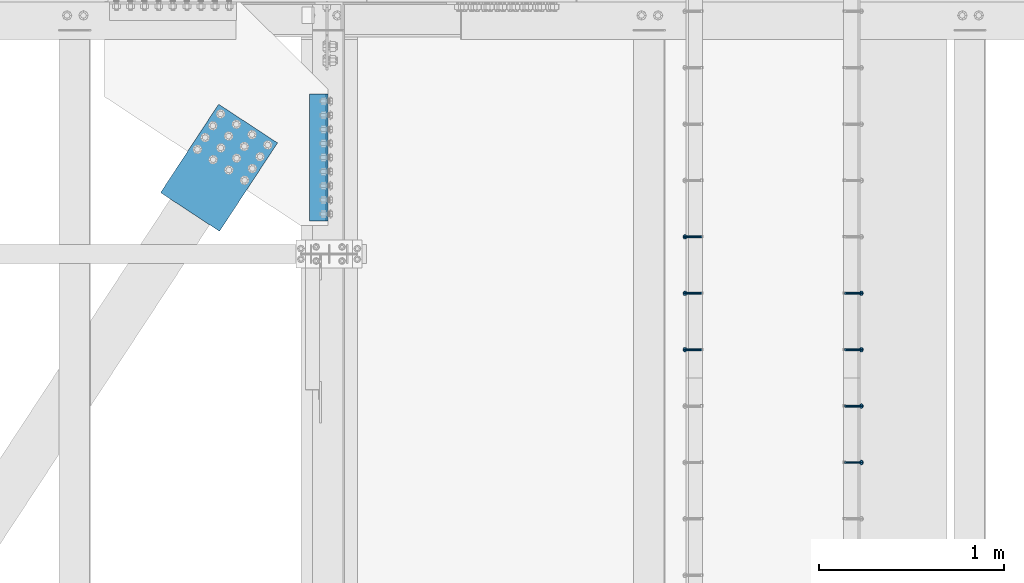
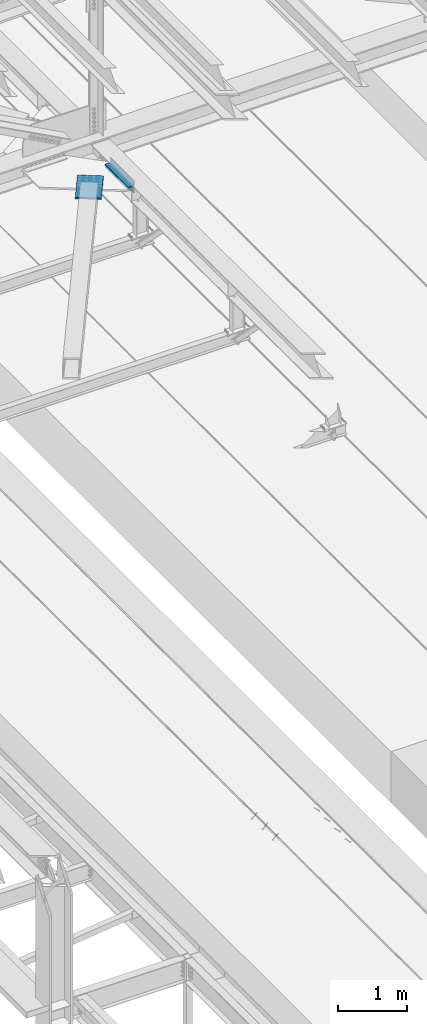
# One storey, part 2374 of 3843: 7 members, 3 beams, 5 elements without a shape of their own.
"""IFC2X3 building model written with IfcOpenShell, lengths in millimetres."""

from ifc_helpers import new_model, si_unit, frame, origin_with_axes, place, context, subcontext, project, spatial, faceted_brep, material, type_object, element, aggregate, save


model = new_model("IFC2X3")

# Units and contexts
model_context = context("Model", 3, precision=1e-05, world=origin_with_axes())
body_context = subcontext(model_context, "Body", "Model", "MODEL_VIEW")
ifc_project = project(units=[si_unit("LENGTHUNIT", "METRE", prefix="MILLI"), si_unit("AREAUNIT", "SQUARE_METRE"), si_unit("VOLUMEUNIT", "CUBIC_METRE"), si_unit("MASSUNIT", "GRAM", prefix="KILO"), si_unit("TIMEUNIT", "SECOND"), si_unit("PLANEANGLEUNIT", "RADIAN"), si_unit("SOLIDANGLEUNIT", "STERADIAN"), si_unit("THERMODYNAMICTEMPERATUREUNIT", "DEGREE_CELSIUS"), si_unit("LUMINOUSINTENSITYUNIT", "LUMEN")], contexts=[model_context])

# Site, building, storey
site_placement = place(None, origin_with_axes())
site = spatial("IfcSite", under=ifc_project, at=site_placement, CompositionType="ELEMENT")
building_placement = place(site_placement, origin_with_axes())
building = spatial("IfcBuilding", under=site, at=building_placement, Name="Undefined", CompositionType="ELEMENT")
storey_placement = place(building_placement, origin_with_axes())
storey = spatial("IfcBuildingStorey", under=building, at=storey_placement, Name="Undefined", CompositionType="ELEMENT", Elevation=0.0)

# Assembly, members
assembly_1_placement = place(storey_placement, origin_with_axes())
assembly_1 = element("IfcElementAssembly", 1, at=assembly_1_placement, inside=storey, Name="EMBED_ANGLE", AssemblyPlace="NOTDEFINED", PredefinedType="RIGID_FRAME")
ifc_material_1 = material(Name="STEEL/A108")
member_type = type_object("IfcMemberType", PredefinedType="NOTDEFINED")
member_1_placement = place(assembly_1_placement, frame((44851.3834999999, 64773.175189209, 30456.1875), z_axis=(0.0, 1.0, 0.0), x_axis=(0.707106781186548, 0.0, -0.707106781186548)))
member_1 = element("IfcMember", 2, at=member_1_placement, type_object=member_type, material=ifc_material_1, Name="HEADED STUD ANCHOR", context=body_context, shape_type="Brep", body=[
    faceted_brep([(7.27595761418343e-12, -3.18000006675175, 5.5), (0.0, -5.49999999998363, 3.1800000667572), (118.110000000976, -5.49999999999091, 3.1800000667572), (118.110000000983, -3.18000006675175, 5.5), (0.0, -6.3499999046162, 0.0), (118.110000000968, -6.34999990461256, 0.0), (0.0, -5.49999999998363, -3.1800000667572), (118.110000000976, -5.49999999999091, -3.1800000667572), (7.27595761418343e-12, -3.18000006675175, -5.5), (118.110000000983, -3.18000006675175, -5.5), (7.27595761418343e-12, -1.81898940354586e-12, -6.34999990463257), (118.110000000968, -1.81898940354586e-12, -6.34999990463257), (0.0, 3.18000006675175, -5.5), (118.110000000968, 3.18000006674811, -5.5), (7.27595761418343e-12, 5.49999999998363, -3.1800000667572), (118.110000000983, 5.49999999998363, -3.1800000667572), (7.27595761418343e-12, 6.3499999046162, 0.0), (118.110000000976, 6.34999990461256, 0.0), (7.27595761418343e-12, 5.49999999998363, 3.1800000667572), (118.110000000983, 5.49999999998363, 3.1800000667572), (0.0, 3.18000006675175, 5.5), (118.110000000968, 3.18000006674811, 5.5), (7.27595761418343e-12, -1.81898940354586e-12, 6.34999990463257), (118.110000000968, -1.81898940354586e-12, 6.34999990463257), (120.650000000991, -10.9899997710909, 6.34999990463257), (120.650000000998, -6.34000015257152, 10.9899997711182), (120.650000000991, -12.6999998092379, 0.0), (120.650000000991, -10.9899997710909, -6.34999990463257), (120.650000000998, -6.34000015257152, -10.9899997711182), (120.650000000991, -1.81898940354586e-12, -12.6899995803833), (120.650000000991, 6.34000015257152, -10.9899997711182), (120.650000000998, 10.9899997710909, -6.34999990463257), (120.650000000991, 12.6999998092342, 0.0), (120.650000000998, 10.9899997710909, 6.34999990463257), (120.650000000991, 6.34000015257152, 10.9899997711182), (120.650000000991, -1.81898940354586e-12, 12.6899995803833), (127.000000001048, -10.9899997710945, 6.34999990463257), (127.000000001048, -6.34000015257152, 10.9899997711182), (127.000000001048, -12.6999998092342, 0.0), (127.000000001048, -10.9899997710945, -6.34999990463257), (127.000000001048, -6.34000015257152, -10.9899997711182), (127.000000001048, 1.81898940354586e-12, -12.6899995803833), (127.000000001048, 6.34000015256788, -10.9899997711182), (127.000000001048, 10.9899997710909, -6.34999990463257), (127.000000001048, 12.6999998092379, 0.0), (127.000000001048, 10.9899997710909, 6.34999990463257), (127.000000001048, 6.34000015256788, 10.9899997711182), (127.000000001048, 1.81898940354586e-12, 12.6899995803833)], [[[0, 1, 2, 3]], [[1, 4, 5, 2]], [[4, 6, 7, 5]], [[6, 8, 9, 7]], [[8, 10, 11, 9]], [[10, 12, 13, 11]], [[12, 14, 15, 13]], [[14, 16, 17, 15]], [[16, 18, 19, 17]], [[18, 20, 21, 19]], [[20, 22, 23, 21]], [[22, 0, 3, 23]], [[22, 20, 18, 16, 14, 12, 10, 8, 6, 4, 1, 0]], [[3, 2, 24, 25]], [[2, 5, 26, 24]], [[5, 7, 27, 26]], [[7, 9, 28, 27]], [[9, 11, 29, 28]], [[11, 13, 30, 29]], [[13, 15, 31, 30]], [[15, 17, 32, 31]], [[17, 19, 33, 32]], [[19, 21, 34, 33]], [[21, 23, 35, 34]], [[23, 3, 25, 35]], [[25, 24, 36, 37]], [[24, 26, 38, 36]], [[26, 27, 39, 38]], [[27, 28, 40, 39]], [[28, 29, 41, 40]], [[29, 30, 42, 41]], [[30, 31, 43, 42]], [[31, 32, 44, 43]], [[32, 33, 45, 44]], [[33, 34, 46, 45]], [[34, 35, 47, 46]], [[35, 25, 37, 47]], [[38, 39, 40, 41, 42, 43, 44, 45, 46, 47, 37, 36]]]),
])
member_2_placement = place(assembly_1_placement, frame((44851.3834999999, 65077.975189209, 30456.1875), z_axis=(0.0, 1.0, 0.0), x_axis=(0.707106781186548, 0.0, -0.707106781186548)))
member_2 = element("IfcMember", 3, at=member_2_placement, type_object=member_type, material=ifc_material_1, Name="HEADED STUD ANCHOR", context=body_context, shape_type="Brep", body=[
    faceted_brep([(7.27595761418343e-12, -3.18000006675175, 5.5), (0.0, -5.49999999998363, 3.1800000667572), (118.110000000976, -5.49999999999091, 3.1800000667572), (118.110000000983, -3.18000006675175, 5.5), (0.0, -6.3499999046162, 0.0), (118.110000000968, -6.34999990461256, 0.0), (0.0, -5.49999999998363, -3.1800000667572), (118.110000000976, -5.49999999999091, -3.1800000667572), (7.27595761418343e-12, -3.18000006675175, -5.5), (118.110000000983, -3.18000006675175, -5.5), (7.27595761418343e-12, -1.81898940354586e-12, -6.34999990463257), (118.110000000968, -1.81898940354586e-12, -6.34999990463257), (0.0, 3.18000006675175, -5.5), (118.110000000968, 3.18000006674811, -5.5), (7.27595761418343e-12, 5.49999999998363, -3.1800000667572), (118.110000000983, 5.49999999998363, -3.1800000667572), (7.27595761418343e-12, 6.3499999046162, 0.0), (118.110000000976, 6.34999990461256, 0.0), (7.27595761418343e-12, 5.49999999998363, 3.1800000667572), (118.110000000983, 5.49999999998363, 3.1800000667572), (0.0, 3.18000006675175, 5.5), (118.110000000968, 3.18000006674811, 5.5), (7.27595761418343e-12, -1.81898940354586e-12, 6.34999990463257), (118.110000000968, -1.81898940354586e-12, 6.34999990463257), (120.650000000991, -10.9899997710909, 6.34999990463257), (120.650000000998, -6.34000015257152, 10.9899997711182), (120.650000000991, -12.6999998092379, 0.0), (120.650000000991, -10.9899997710909, -6.34999990463257), (120.650000000998, -6.34000015257152, -10.9899997711182), (120.650000000991, -1.81898940354586e-12, -12.6899995803833), (120.650000000991, 6.34000015257152, -10.9899997711182), (120.650000000998, 10.9899997710909, -6.34999990463257), (120.650000000991, 12.6999998092342, 0.0), (120.650000000998, 10.9899997710909, 6.34999990463257), (120.650000000991, 6.34000015257152, 10.9899997711182), (120.650000000991, -1.81898940354586e-12, 12.6899995803833), (127.000000001048, -10.9899997710945, 6.34999990463257), (127.000000001048, -6.34000015257152, 10.9899997711182), (127.000000001048, -12.6999998092342, 0.0), (127.000000001048, -10.9899997710945, -6.34999990463257), (127.000000001048, -6.34000015257152, -10.9899997711182), (127.000000001048, 1.81898940354586e-12, -12.6899995803833), (127.000000001048, 6.34000015256788, -10.9899997711182), (127.000000001048, 10.9899997710909, -6.34999990463257), (127.000000001048, 12.6999998092379, 0.0), (127.000000001048, 10.9899997710909, 6.34999990463257), (127.000000001048, 6.34000015256788, 10.9899997711182), (127.000000001048, 1.81898940354586e-12, 12.6899995803833)], [[[0, 1, 2, 3]], [[1, 4, 5, 2]], [[4, 6, 7, 5]], [[6, 8, 9, 7]], [[8, 10, 11, 9]], [[10, 12, 13, 11]], [[12, 14, 15, 13]], [[14, 16, 17, 15]], [[16, 18, 19, 17]], [[18, 20, 21, 19]], [[20, 22, 23, 21]], [[22, 0, 3, 23]], [[22, 20, 18, 16, 14, 12, 10, 8, 6, 4, 1, 0]], [[3, 2, 24, 25]], [[2, 5, 26, 24]], [[5, 7, 27, 26]], [[7, 9, 28, 27]], [[9, 11, 29, 28]], [[11, 13, 30, 29]], [[13, 15, 31, 30]], [[15, 17, 32, 31]], [[17, 19, 33, 32]], [[19, 21, 34, 33]], [[21, 23, 35, 34]], [[23, 3, 25, 35]], [[25, 24, 36, 37]], [[24, 26, 38, 36]], [[26, 27, 39, 38]], [[27, 28, 40, 39]], [[28, 29, 41, 40]], [[29, 30, 42, 41]], [[30, 31, 43, 42]], [[31, 32, 44, 43]], [[32, 33, 45, 44]], [[33, 34, 46, 45]], [[34, 35, 47, 46]], [[35, 25, 37, 47]], [[38, 39, 40, 41, 42, 43, 44, 45, 46, 47, 37, 36]]]),
])
aggregate(assembly_1, [member_1, member_2])

assembly_2_placement = place(storey_placement, origin_with_axes())
assembly_2 = element("IfcElementAssembly", 4, at=assembly_2_placement, inside=storey, Name="EMBED_ANGLE", AssemblyPlace="NOTDEFINED", PredefinedType="RIGID_FRAME")
member_3_placement = place(assembly_2_placement, frame((44851.3834999999, 65382.775189209, 30456.1875), z_axis=(0.0, 1.0, 0.0), x_axis=(0.707106781186548, 0.0, -0.707106781186548)))
member_3 = element("IfcMember", 5, at=member_3_placement, type_object=member_type, material=ifc_material_1, Name="HEADED STUD ANCHOR", context=body_context, shape_type="Brep", body=[
    faceted_brep([(7.27595761418343e-12, -3.18000006675175, 5.5), (0.0, -5.49999999998363, 3.1800000667572), (118.110000000976, -5.49999999999091, 3.1800000667572), (118.110000000983, -3.18000006675175, 5.5), (0.0, -6.3499999046162, 0.0), (118.110000000968, -6.34999990461256, 0.0), (0.0, -5.49999999998363, -3.1800000667572), (118.110000000976, -5.49999999999091, -3.1800000667572), (7.27595761418343e-12, -3.18000006675175, -5.5), (118.110000000983, -3.18000006675175, -5.5), (7.27595761418343e-12, -1.81898940354586e-12, -6.34999990463257), (118.110000000968, -1.81898940354586e-12, -6.34999990463257), (0.0, 3.18000006675175, -5.5), (118.110000000968, 3.18000006674811, -5.5), (7.27595761418343e-12, 5.49999999998363, -3.1800000667572), (118.110000000983, 5.49999999998363, -3.1800000667572), (7.27595761418343e-12, 6.3499999046162, 0.0), (118.110000000976, 6.34999990461256, 0.0), (7.27595761418343e-12, 5.49999999998363, 3.1800000667572), (118.110000000983, 5.49999999998363, 3.1800000667572), (0.0, 3.18000006675175, 5.5), (118.110000000968, 3.18000006674811, 5.5), (7.27595761418343e-12, -1.81898940354586e-12, 6.34999990463257), (118.110000000968, -1.81898940354586e-12, 6.34999990463257), (120.650000000991, -10.9899997710909, 6.34999990463257), (120.650000000998, -6.34000015257152, 10.9899997711182), (120.650000000991, -12.6999998092379, 0.0), (120.650000000991, -10.9899997710909, -6.34999990463257), (120.650000000998, -6.34000015257152, -10.9899997711182), (120.650000000991, -1.81898940354586e-12, -12.6899995803833), (120.650000000991, 6.34000015257152, -10.9899997711182), (120.650000000998, 10.9899997710909, -6.34999990463257), (120.650000000991, 12.6999998092342, 0.0), (120.650000000998, 10.9899997710909, 6.34999990463257), (120.650000000991, 6.34000015257152, 10.9899997711182), (120.650000000991, -1.81898940354586e-12, 12.6899995803833), (127.000000001048, -10.9899997710945, 6.34999990463257), (127.000000001048, -6.34000015257152, 10.9899997711182), (127.000000001048, -12.6999998092342, 0.0), (127.000000001048, -10.9899997710945, -6.34999990463257), (127.000000001048, -6.34000015257152, -10.9899997711182), (127.000000001048, 1.81898940354586e-12, -12.6899995803833), (127.000000001048, 6.34000015256788, -10.9899997711182), (127.000000001048, 10.9899997710909, -6.34999990463257), (127.000000001048, 12.6999998092379, 0.0), (127.000000001048, 10.9899997710909, 6.34999990463257), (127.000000001048, 6.34000015256788, 10.9899997711182), (127.000000001048, 1.81898940354586e-12, 12.6899995803833)], [[[0, 1, 2, 3]], [[1, 4, 5, 2]], [[4, 6, 7, 5]], [[6, 8, 9, 7]], [[8, 10, 11, 9]], [[10, 12, 13, 11]], [[12, 14, 15, 13]], [[14, 16, 17, 15]], [[16, 18, 19, 17]], [[18, 20, 21, 19]], [[20, 22, 23, 21]], [[22, 0, 3, 23]], [[22, 20, 18, 16, 14, 12, 10, 8, 6, 4, 1, 0]], [[3, 2, 24, 25]], [[2, 5, 26, 24]], [[5, 7, 27, 26]], [[7, 9, 28, 27]], [[9, 11, 29, 28]], [[11, 13, 30, 29]], [[13, 15, 31, 30]], [[15, 17, 32, 31]], [[17, 19, 33, 32]], [[19, 21, 34, 33]], [[21, 23, 35, 34]], [[23, 3, 25, 35]], [[25, 24, 36, 37]], [[24, 26, 38, 36]], [[26, 27, 39, 38]], [[27, 28, 40, 39]], [[28, 29, 41, 40]], [[29, 30, 42, 41]], [[30, 31, 43, 42]], [[31, 32, 44, 43]], [[32, 33, 45, 44]], [[33, 34, 46, 45]], [[34, 35, 47, 46]], [[35, 25, 37, 47]], [[38, 39, 40, 41, 42, 43, 44, 45, 46, 47, 37, 36]]]),
])
member_4_placement = place(assembly_2_placement, frame((44851.3834999999, 65687.575189209, 30456.1875), z_axis=(0.0, 1.0, 0.0), x_axis=(0.707106781186548, 0.0, -0.707106781186548)))
member_4 = element("IfcMember", 6, at=member_4_placement, type_object=member_type, material=ifc_material_1, Name="HEADED STUD ANCHOR", context=body_context, shape_type="Brep", body=[
    faceted_brep([(7.27595761418343e-12, -3.18000006675175, 5.5), (0.0, -5.49999999998363, 3.1800000667572), (118.110000000976, -5.49999999999091, 3.1800000667572), (118.110000000983, -3.18000006675175, 5.5), (0.0, -6.3499999046162, 0.0), (118.110000000968, -6.34999990461256, 0.0), (0.0, -5.49999999998363, -3.1800000667572), (118.110000000976, -5.49999999999091, -3.1800000667572), (7.27595761418343e-12, -3.18000006675175, -5.5), (118.110000000983, -3.18000006675175, -5.5), (7.27595761418343e-12, -1.81898940354586e-12, -6.34999990463257), (118.110000000968, -1.81898940354586e-12, -6.34999990463257), (0.0, 3.18000006675175, -5.5), (118.110000000968, 3.18000006674811, -5.5), (7.27595761418343e-12, 5.49999999998363, -3.1800000667572), (118.110000000983, 5.49999999998363, -3.1800000667572), (7.27595761418343e-12, 6.3499999046162, 0.0), (118.110000000976, 6.34999990461256, 0.0), (7.27595761418343e-12, 5.49999999998363, 3.1800000667572), (118.110000000983, 5.49999999998363, 3.1800000667572), (0.0, 3.18000006675175, 5.5), (118.110000000968, 3.18000006674811, 5.5), (7.27595761418343e-12, -1.81898940354586e-12, 6.34999990463257), (118.110000000968, -1.81898940354586e-12, 6.34999990463257), (120.650000000991, -10.9899997710909, 6.34999990463257), (120.650000000998, -6.34000015257152, 10.9899997711182), (120.650000000991, -12.6999998092379, 0.0), (120.650000000991, -10.9899997710909, -6.34999990463257), (120.650000000998, -6.34000015257152, -10.9899997711182), (120.650000000991, -1.81898940354586e-12, -12.6899995803833), (120.650000000991, 6.34000015257152, -10.9899997711182), (120.650000000998, 10.9899997710909, -6.34999990463257), (120.650000000991, 12.6999998092342, 0.0), (120.650000000998, 10.9899997710909, 6.34999990463257), (120.650000000991, 6.34000015257152, 10.9899997711182), (120.650000000991, -1.81898940354586e-12, 12.6899995803833), (127.000000001048, -10.9899997710945, 6.34999990463257), (127.000000001048, -6.34000015257152, 10.9899997711182), (127.000000001048, -12.6999998092342, 0.0), (127.000000001048, -10.9899997710945, -6.34999990463257), (127.000000001048, -6.34000015257152, -10.9899997711182), (127.000000001048, 1.81898940354586e-12, -12.6899995803833), (127.000000001048, 6.34000015256788, -10.9899997711182), (127.000000001048, 10.9899997710909, -6.34999990463257), (127.000000001048, 12.6999998092379, 0.0), (127.000000001048, 10.9899997710909, 6.34999990463257), (127.000000001048, 6.34000015256788, 10.9899997711182), (127.000000001048, 1.81898940354586e-12, 12.6899995803833)], [[[0, 1, 2, 3]], [[1, 4, 5, 2]], [[4, 6, 7, 5]], [[6, 8, 9, 7]], [[8, 10, 11, 9]], [[10, 12, 13, 11]], [[12, 14, 15, 13]], [[14, 16, 17, 15]], [[16, 18, 19, 17]], [[18, 20, 21, 19]], [[20, 22, 23, 21]], [[22, 0, 3, 23]], [[22, 20, 18, 16, 14, 12, 10, 8, 6, 4, 1, 0]], [[3, 2, 24, 25]], [[2, 5, 26, 24]], [[5, 7, 27, 26]], [[7, 9, 28, 27]], [[9, 11, 29, 28]], [[11, 13, 30, 29]], [[13, 15, 31, 30]], [[15, 17, 32, 31]], [[17, 19, 33, 32]], [[19, 21, 34, 33]], [[21, 23, 35, 34]], [[23, 3, 25, 35]], [[25, 24, 36, 37]], [[24, 26, 38, 36]], [[26, 27, 39, 38]], [[27, 28, 40, 39]], [[28, 29, 41, 40]], [[29, 30, 42, 41]], [[30, 31, 43, 42]], [[31, 32, 44, 43]], [[32, 33, 45, 44]], [[33, 34, 46, 45]], [[34, 35, 47, 46]], [[35, 25, 37, 47]], [[38, 39, 40, 41, 42, 43, 44, 45, 46, 47, 37, 36]]]),
])
aggregate(assembly_2, [member_3, member_4])

assembly_3_placement = place(storey_placement, origin_with_axes())
assembly_3 = element("IfcElementAssembly", 7, at=assembly_3_placement, inside=storey, Name="EMBED_ANGLE", AssemblyPlace="NOTDEFINED", PredefinedType="RIGID_FRAME")
member_5_placement = place(assembly_3_placement, frame((44073.5085000003, 65382.775189209, 30456.1874999998), z_axis=(0.0, -1.0, 0.0), x_axis=(-0.707106781186548, 0.0, -0.707106781186548)))
member_5 = element("IfcMember", 8, at=member_5_placement, type_object=member_type, material=ifc_material_1, Name="HEADED STUD ANCHOR", context=body_context, shape_type="Brep", body=[
    faceted_brep([(7.27595761418343e-12, -3.18000006675175, 5.5), (0.0, -5.49999999998363, 3.1800000667572), (118.110000000976, -5.49999999999091, 3.1800000667572), (118.110000000983, -3.18000006675175, 5.5), (0.0, -6.3499999046162, 0.0), (118.110000000968, -6.34999990461256, 0.0), (0.0, -5.49999999998363, -3.1800000667572), (118.110000000976, -5.49999999999091, -3.1800000667572), (7.27595761418343e-12, -3.18000006675175, -5.5), (118.110000000983, -3.18000006675175, -5.5), (7.27595761418343e-12, -1.81898940354586e-12, -6.34999990463257), (118.110000000968, -1.81898940354586e-12, -6.34999990463257), (0.0, 3.18000006675175, -5.5), (118.110000000968, 3.18000006674811, -5.5), (7.27595761418343e-12, 5.49999999998363, -3.1800000667572), (118.110000000983, 5.49999999998363, -3.1800000667572), (7.27595761418343e-12, 6.3499999046162, 0.0), (118.110000000976, 6.34999990461256, 0.0), (7.27595761418343e-12, 5.49999999998363, 3.1800000667572), (118.110000000983, 5.49999999998363, 3.1800000667572), (0.0, 3.18000006675175, 5.5), (118.110000000968, 3.18000006674811, 5.5), (7.27595761418343e-12, -1.81898940354586e-12, 6.34999990463257), (118.110000000968, -1.81898940354586e-12, 6.34999990463257), (120.650000000991, -10.9899997710909, 6.34999990463257), (120.650000000998, -6.34000015257152, 10.9899997711182), (120.650000000991, -12.6999998092379, 0.0), (120.650000000991, -10.9899997710909, -6.34999990463257), (120.650000000998, -6.34000015257152, -10.9899997711182), (120.650000000991, -1.81898940354586e-12, -12.6899995803833), (120.650000000991, 6.34000015257152, -10.9899997711182), (120.650000000998, 10.9899997710909, -6.34999990463257), (120.650000000991, 12.6999998092342, 0.0), (120.650000000998, 10.9899997710909, 6.34999990463257), (120.650000000991, 6.34000015257152, 10.9899997711182), (120.650000000991, -1.81898940354586e-12, 12.6899995803833), (127.000000001048, -10.9899997710945, 6.34999990463257), (127.000000001048, -6.34000015257152, 10.9899997711182), (127.000000001048, -12.6999998092342, 0.0), (127.000000001048, -10.9899997710945, -6.34999990463257), (127.000000001048, -6.34000015257152, -10.9899997711182), (127.000000001048, 1.81898940354586e-12, -12.6899995803833), (127.000000001048, 6.34000015256788, -10.9899997711182), (127.000000001048, 10.9899997710909, -6.34999990463257), (127.000000001048, 12.6999998092379, 0.0), (127.000000001048, 10.9899997710909, 6.34999990463257), (127.000000001048, 6.34000015256788, 10.9899997711182), (127.000000001048, 1.81898940354586e-12, 12.6899995803833)], [[[0, 1, 2, 3]], [[1, 4, 5, 2]], [[4, 6, 7, 5]], [[6, 8, 9, 7]], [[8, 10, 11, 9]], [[10, 12, 13, 11]], [[12, 14, 15, 13]], [[14, 16, 17, 15]], [[16, 18, 19, 17]], [[18, 20, 21, 19]], [[20, 22, 23, 21]], [[22, 0, 3, 23]], [[22, 20, 18, 16, 14, 12, 10, 8, 6, 4, 1, 0]], [[3, 2, 24, 25]], [[2, 5, 26, 24]], [[5, 7, 27, 26]], [[7, 9, 28, 27]], [[9, 11, 29, 28]], [[11, 13, 30, 29]], [[13, 15, 31, 30]], [[15, 17, 32, 31]], [[17, 19, 33, 32]], [[19, 21, 34, 33]], [[21, 23, 35, 34]], [[23, 3, 25, 35]], [[25, 24, 36, 37]], [[24, 26, 38, 36]], [[26, 27, 39, 38]], [[27, 28, 40, 39]], [[28, 29, 41, 40]], [[29, 30, 42, 41]], [[30, 31, 43, 42]], [[31, 32, 44, 43]], [[32, 33, 45, 44]], [[33, 34, 46, 45]], [[34, 35, 47, 46]], [[35, 25, 37, 47]], [[38, 39, 40, 41, 42, 43, 44, 45, 46, 47, 37, 36]]]),
])
member_6_placement = place(assembly_3_placement, frame((44073.5085000003, 65687.575189209, 30456.1874999998), z_axis=(0.0, -1.0, 0.0), x_axis=(-0.707106781186548, 0.0, -0.707106781186548)))
member_6 = element("IfcMember", 9, at=member_6_placement, type_object=member_type, material=ifc_material_1, Name="HEADED STUD ANCHOR", context=body_context, shape_type="Brep", body=[
    faceted_brep([(7.27595761418343e-12, -3.18000006675175, 5.5), (0.0, -5.49999999998363, 3.1800000667572), (118.110000000976, -5.49999999999091, 3.1800000667572), (118.110000000983, -3.18000006675175, 5.5), (0.0, -6.3499999046162, 0.0), (118.110000000968, -6.34999990461256, 0.0), (0.0, -5.49999999998363, -3.1800000667572), (118.110000000976, -5.49999999999091, -3.1800000667572), (7.27595761418343e-12, -3.18000006675175, -5.5), (118.110000000983, -3.18000006675175, -5.5), (7.27595761418343e-12, -1.81898940354586e-12, -6.34999990463257), (118.110000000968, -1.81898940354586e-12, -6.34999990463257), (0.0, 3.18000006675175, -5.5), (118.110000000968, 3.18000006674811, -5.5), (7.27595761418343e-12, 5.49999999998363, -3.1800000667572), (118.110000000983, 5.49999999998363, -3.1800000667572), (7.27595761418343e-12, 6.3499999046162, 0.0), (118.110000000976, 6.34999990461256, 0.0), (7.27595761418343e-12, 5.49999999998363, 3.1800000667572), (118.110000000983, 5.49999999998363, 3.1800000667572), (0.0, 3.18000006675175, 5.5), (118.110000000968, 3.18000006674811, 5.5), (7.27595761418343e-12, -1.81898940354586e-12, 6.34999990463257), (118.110000000968, -1.81898940354586e-12, 6.34999990463257), (120.650000000991, -10.9899997710909, 6.34999990463257), (120.650000000998, -6.34000015257152, 10.9899997711182), (120.650000000991, -12.6999998092379, 0.0), (120.650000000991, -10.9899997710909, -6.34999990463257), (120.650000000998, -6.34000015257152, -10.9899997711182), (120.650000000991, -1.81898940354586e-12, -12.6899995803833), (120.650000000991, 6.34000015257152, -10.9899997711182), (120.650000000998, 10.9899997710909, -6.34999990463257), (120.650000000991, 12.6999998092342, 0.0), (120.650000000998, 10.9899997710909, 6.34999990463257), (120.650000000991, 6.34000015257152, 10.9899997711182), (120.650000000991, -1.81898940354586e-12, 12.6899995803833), (127.000000001048, -10.9899997710945, 6.34999990463257), (127.000000001048, -6.34000015257152, 10.9899997711182), (127.000000001048, -12.6999998092342, 0.0), (127.000000001048, -10.9899997710945, -6.34999990463257), (127.000000001048, -6.34000015257152, -10.9899997711182), (127.000000001048, 1.81898940354586e-12, -12.6899995803833), (127.000000001048, 6.34000015256788, -10.9899997711182), (127.000000001048, 10.9899997710909, -6.34999990463257), (127.000000001048, 12.6999998092379, 0.0), (127.000000001048, 10.9899997710909, 6.34999990463257), (127.000000001048, 6.34000015256788, 10.9899997711182), (127.000000001048, 1.81898940354586e-12, 12.6899995803833)], [[[0, 1, 2, 3]], [[1, 4, 5, 2]], [[4, 6, 7, 5]], [[6, 8, 9, 7]], [[8, 10, 11, 9]], [[10, 12, 13, 11]], [[12, 14, 15, 13]], [[14, 16, 17, 15]], [[16, 18, 19, 17]], [[18, 20, 21, 19]], [[20, 22, 23, 21]], [[22, 0, 3, 23]], [[22, 20, 18, 16, 14, 12, 10, 8, 6, 4, 1, 0]], [[3, 2, 24, 25]], [[2, 5, 26, 24]], [[5, 7, 27, 26]], [[7, 9, 28, 27]], [[9, 11, 29, 28]], [[11, 13, 30, 29]], [[13, 15, 31, 30]], [[15, 17, 32, 31]], [[17, 19, 33, 32]], [[19, 21, 34, 33]], [[21, 23, 35, 34]], [[23, 3, 25, 35]], [[25, 24, 36, 37]], [[24, 26, 38, 36]], [[26, 27, 39, 38]], [[27, 28, 40, 39]], [[28, 29, 41, 40]], [[29, 30, 42, 41]], [[30, 31, 43, 42]], [[31, 32, 44, 43]], [[32, 33, 45, 44]], [[33, 34, 46, 45]], [[34, 35, 47, 46]], [[35, 25, 37, 47]], [[38, 39, 40, 41, 42, 43, 44, 45, 46, 47, 37, 36]]]),
])
member_7_placement = place(assembly_3_placement, frame((44073.5085000003, 65992.375189209, 30456.1874999998), z_axis=(0.0, -1.0, 0.0), x_axis=(-0.707106781186548, 0.0, -0.707106781186548)))
member_7 = element("IfcMember", 10, at=member_7_placement, type_object=member_type, material=ifc_material_1, Name="HEADED STUD ANCHOR", context=body_context, shape_type="Brep", body=[
    faceted_brep([(7.27595761418343e-12, -3.18000006675175, 5.5), (0.0, -5.49999999998363, 3.1800000667572), (118.110000000976, -5.49999999999091, 3.1800000667572), (118.110000000983, -3.18000006675175, 5.5), (0.0, -6.3499999046162, 0.0), (118.110000000968, -6.34999990461256, 0.0), (0.0, -5.49999999998363, -3.1800000667572), (118.110000000976, -5.49999999999091, -3.1800000667572), (7.27595761418343e-12, -3.18000006675175, -5.5), (118.110000000983, -3.18000006675175, -5.5), (7.27595761418343e-12, -1.81898940354586e-12, -6.34999990463257), (118.110000000968, -1.81898940354586e-12, -6.34999990463257), (0.0, 3.18000006675175, -5.5), (118.110000000968, 3.18000006674811, -5.5), (7.27595761418343e-12, 5.49999999998363, -3.1800000667572), (118.110000000983, 5.49999999998363, -3.1800000667572), (7.27595761418343e-12, 6.3499999046162, 0.0), (118.110000000976, 6.34999990461256, 0.0), (7.27595761418343e-12, 5.49999999998363, 3.1800000667572), (118.110000000983, 5.49999999998363, 3.1800000667572), (0.0, 3.18000006675175, 5.5), (118.110000000968, 3.18000006674811, 5.5), (7.27595761418343e-12, -1.81898940354586e-12, 6.34999990463257), (118.110000000968, -1.81898940354586e-12, 6.34999990463257), (120.650000000991, -10.9899997710909, 6.34999990463257), (120.650000000998, -6.34000015257152, 10.9899997711182), (120.650000000991, -12.6999998092379, 0.0), (120.650000000991, -10.9899997710909, -6.34999990463257), (120.650000000998, -6.34000015257152, -10.9899997711182), (120.650000000991, -1.81898940354586e-12, -12.6899995803833), (120.650000000991, 6.34000015257152, -10.9899997711182), (120.650000000998, 10.9899997710909, -6.34999990463257), (120.650000000991, 12.6999998092342, 0.0), (120.650000000998, 10.9899997710909, 6.34999990463257), (120.650000000991, 6.34000015257152, 10.9899997711182), (120.650000000991, -1.81898940354586e-12, 12.6899995803833), (127.000000001048, -10.9899997710945, 6.34999990463257), (127.000000001048, -6.34000015257152, 10.9899997711182), (127.000000001048, -12.6999998092342, 0.0), (127.000000001048, -10.9899997710945, -6.34999990463257), (127.000000001048, -6.34000015257152, -10.9899997711182), (127.000000001048, 1.81898940354586e-12, -12.6899995803833), (127.000000001048, 6.34000015256788, -10.9899997711182), (127.000000001048, 10.9899997710909, -6.34999990463257), (127.000000001048, 12.6999998092379, 0.0), (127.000000001048, 10.9899997710909, 6.34999990463257), (127.000000001048, 6.34000015256788, 10.9899997711182), (127.000000001048, 1.81898940354586e-12, 12.6899995803833)], [[[0, 1, 2, 3]], [[1, 4, 5, 2]], [[4, 6, 7, 5]], [[6, 8, 9, 7]], [[8, 10, 11, 9]], [[10, 12, 13, 11]], [[12, 14, 15, 13]], [[14, 16, 17, 15]], [[16, 18, 19, 17]], [[18, 20, 21, 19]], [[20, 22, 23, 21]], [[22, 0, 3, 23]], [[22, 20, 18, 16, 14, 12, 10, 8, 6, 4, 1, 0]], [[3, 2, 24, 25]], [[2, 5, 26, 24]], [[5, 7, 27, 26]], [[7, 9, 28, 27]], [[9, 11, 29, 28]], [[11, 13, 30, 29]], [[13, 15, 31, 30]], [[15, 17, 32, 31]], [[17, 19, 33, 32]], [[19, 21, 34, 33]], [[21, 23, 35, 34]], [[23, 3, 25, 35]], [[25, 24, 36, 37]], [[24, 26, 38, 36]], [[26, 27, 39, 38]], [[27, 28, 40, 39]], [[28, 29, 41, 40]], [[29, 30, 42, 41]], [[30, 31, 43, 42]], [[31, 32, 44, 43]], [[32, 33, 45, 44]], [[33, 34, 46, 45]], [[34, 35, 47, 46]], [[35, 25, 37, 47]], [[38, 39, 40, 41, 42, 43, 44, 45, 46, 47, 37, 36]]]),
])
aggregate(assembly_3, [member_5, member_6, member_7])

# Assembly, beams
assembly_4_placement = place(storey_placement, origin_with_axes())
assembly_4 = element("IfcElementAssembly", 11, at=assembly_4_placement, inside=storey, Name="PLATE", AssemblyPlace="NOTDEFINED", PredefinedType="RIGID_FRAME")
ifc_material_2 = material(Name="STEEL/A572-50")
beam_type_1 = type_object("IfcBeamType", Name="L4X4X1/2", PredefinedType="NOTDEFINED")
beam_1_placement = place(assembly_4_placement, frame((42006.8375, 66078.0999999999, 42297.3500007629), z_axis=(-1.0, 0.0, 0.0), x_axis=(0.0, 1.0, 0.0)))
beam_1 = element("IfcBeam", 12, at=beam_1_placement, type_object=beam_type_1, material=ifc_material_2, Name="ANGLE", ObjectType="L4X4X1/2", context=body_context, shape_type="Brep", body=[
    faceted_brep([(0.0, 50.8000000000029, -50.8000000000029), (0.0, 50.8000000000029, 50.8000000000029), (685.800000000003, 50.8000000000029, 50.8000000000029), (685.800000000003, 50.8000000000029, -50.8000000000029), (0.0, 38.0999999999985, 50.8000000000029), (685.800000000003, 38.0999999999985, 50.8000000000029), (0.0, 38.0999999999985, -38.0999999999985), (685.800000000003, 38.0999999999985, -38.1000000000058), (0.0, -50.8000000000029, -38.1000000000058), (685.800000000003, -50.8000000000029, -38.1000000000058), (0.0, -50.8000000000029, -50.8000000000029), (685.800000000003, -50.8000000000029, -50.8000000000029)], [[[0, 1, 2, 3]], [[1, 4, 5, 2]], [[4, 6, 7, 5]], [[6, 8, 9, 7]], [[8, 10, 11, 9]], [[10, 0, 3, 11]], [[5, 7, 9, 11, 3, 2]], [[10, 8, 6, 4, 1, 0]]]),
])
beam_type_2 = type_object("IfcBeamType", Name="L4X3-1/2X1/2", PredefinedType="NOTDEFINED")
beam_2_placement = place(assembly_4_placement, frame((42006.8375, 66763.8999999999, 42173.5249984741), z_axis=(-1.0, 0.0, 0.0), x_axis=(0.0, -1.0, 0.0)))
beam_2 = element("IfcBeam", 13, at=beam_2_placement, type_object=beam_type_2, material=ifc_material_2, Name="ANGLE", ObjectType="L4X3-1/2X1/2", context=body_context, shape_type="Brep", body=[
    faceted_brep([(0.0, 44.4499999999971, -50.8000000000029), (0.0, 44.4499999999971, 50.8000000000029), (685.800000000003, 44.4499999999971, 50.8000000000029), (685.800000000003, 44.4499999999971, -50.8000000000029), (0.0, 31.75, 50.8000000000029), (685.800000000003, 31.75, 50.8000000000029), (0.0, 31.7500000838336, -38.0999999999985), (685.800000000003, 31.75, -38.0999999999985), (4.36557456851006e-11, -44.4500000000226, -38.0999999999985), (685.800000000003, -44.4499999999971, -38.0999999999985), (0.0, -44.4499999999971, -50.8000000000029), (685.800000000003, -44.4499999999971, -50.8000000000029)], [[[0, 1, 2, 3]], [[1, 4, 5, 2]], [[4, 6, 7, 5]], [[6, 8, 9, 7]], [[8, 10, 11, 9]], [[10, 0, 3, 11]], [[5, 7, 9, 11, 3, 2]], [[10, 8, 6, 4, 1, 0]]]),
])
aggregate(assembly_4, [beam_2, beam_1])

# Assembly, beam
assembly_5_placement = place(storey_placement, origin_with_axes())
assembly_5 = element("IfcElementAssembly", 14, at=assembly_5_placement, inside=storey, AssemblyPlace="NOTDEFINED", PredefinedType="RIGID_FRAME")
beam_type_3 = type_object("IfcBeamType", PredefinedType="NOTDEFINED")
beam_3_placement = place(assembly_5_placement, frame((41624.4299716682, 66604.8067577465, 42259.25), z_axis=(-0.835938629021654, 0.548822930014224, 0.0), x_axis=(-0.548822930014217, -0.835938629021658, 0.0)))
beam_3 = element("IfcBeam", 15, at=beam_3_placement, type_object=beam_type_3, material=ifc_material_2, Name="PLATE", context=body_context, shape_type="Brep", body=[
    faceted_brep([(5.85714587941766e-10, 12.6999999999971, -190.500000000349), (-6.14818418398499e-10, 12.6999999999971, 190.500000000364), (571.499999996191, 12.6999999999971, 190.49999999936), (571.499999997392, 12.6999999999971, -190.500000001353), (-6.14818418398499e-10, -12.6999999999971, 190.500000000364), (571.499999996191, -12.6999999999971, 190.49999999936), (5.85714587941766e-10, -12.6999999999971, -190.500000000349), (571.499999997392, -12.6999999999971, -190.500000001353)], [[[0, 1, 2, 3]], [[1, 4, 5, 2]], [[4, 6, 7, 5]], [[6, 0, 3, 7]], [[5, 7, 3, 2]], [[6, 4, 1, 0]]]),
])
aggregate(assembly_5, [beam_3])

save(model, "model.ifc")
